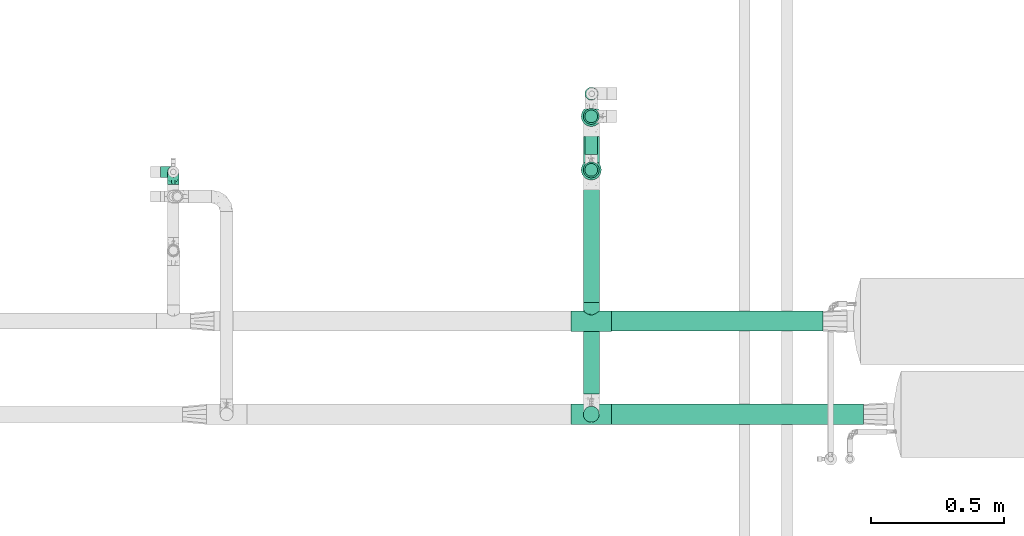
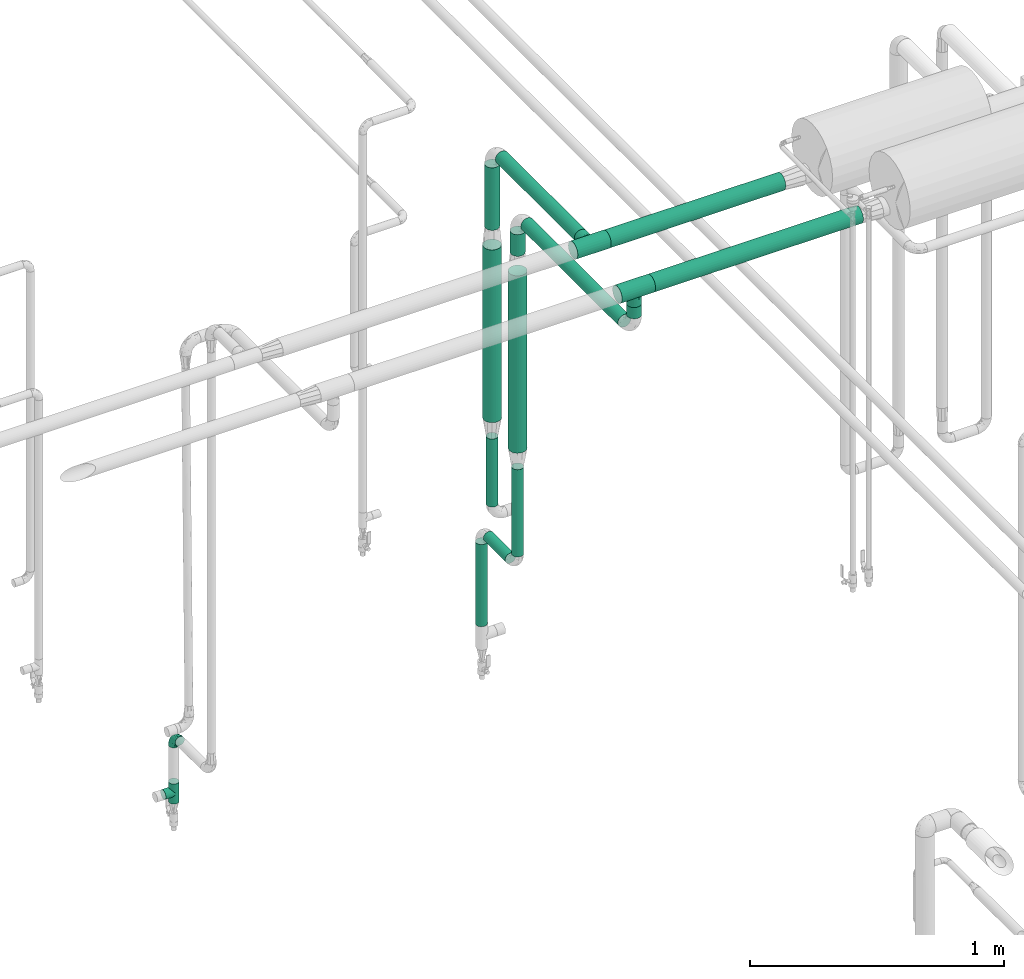
# One storey, part 568 of 827: 13 flow segments, 4 flow fittings.
"""IFC2X3 building model written with IfcOpenShell, lengths in millimetres."""

from ifc_helpers import new_model, entity, si_unit, converted_unit, derived_unit, direction, frame, origin, origin_2d_with_axis, place, context, subcontext, project, spatial, circle, extrude, faceted_brep, source, transform, mapped, material, type_object, type_shapes, element, save


model = new_model("IFC2X3")

# Units and contexts
model_context = context("Model", 3, precision=0.01, world=origin(), true_north=direction((6.12303176911189e-17, 1.0)))
body_context = subcontext(model_context, "Body", "Model", "MODEL_VIEW")
ifc_project = project(units=[si_unit("LENGTHUNIT", "METRE", prefix="MILLI"), si_unit("AREAUNIT", "SQUARE_METRE"), si_unit("VOLUMEUNIT", "CUBIC_METRE"), converted_unit("PLANEANGLEUNIT", "DEGREE", entity("IfcRatioMeasure", 0.0174532925199433), si_unit("PLANEANGLEUNIT", "RADIAN"), dimensions=[0, 0, 0, 0, 0, 0, 0]), si_unit("MASSUNIT", "GRAM", prefix="KILO"), derived_unit("MASSDENSITYUNIT", [(si_unit("MASSUNIT", "GRAM", prefix="KILO"), 1), (si_unit("LENGTHUNIT", "METRE"), -3)]), derived_unit("MOMENTOFINERTIAUNIT", [(si_unit("LENGTHUNIT", "METRE"), 4)]), si_unit("TIMEUNIT", "SECOND"), si_unit("FREQUENCYUNIT", "HERTZ"), si_unit("THERMODYNAMICTEMPERATUREUNIT", "DEGREE_CELSIUS"), derived_unit("THERMALTRANSMITTANCEUNIT", [(si_unit("MASSUNIT", "GRAM", prefix="KILO"), 1), (si_unit("THERMODYNAMICTEMPERATUREUNIT", "KELVIN"), -1), (si_unit("TIMEUNIT", "SECOND"), -3)]), derived_unit("VOLUMETRICFLOWRATEUNIT", [(si_unit("LENGTHUNIT", "METRE"), 3), (si_unit("TIMEUNIT", "SECOND"), -1)]), derived_unit("MASSFLOWRATEUNIT", [(si_unit("MASSUNIT", "GRAM", prefix="KILO"), 1), (si_unit("TIMEUNIT", "SECOND"), -1)]), derived_unit("ROTATIONALFREQUENCYUNIT", [(si_unit("TIMEUNIT", "SECOND"), -1)]), si_unit("ELECTRICCURRENTUNIT", "AMPERE"), si_unit("ELECTRICVOLTAGEUNIT", "VOLT"), si_unit("POWERUNIT", "WATT"), si_unit("FORCEUNIT", "NEWTON", prefix="KILO"), si_unit("ILLUMINANCEUNIT", "LUX"), si_unit("LUMINOUSFLUXUNIT", "LUMEN"), si_unit("LUMINOUSINTENSITYUNIT", "CANDELA"), derived_unit("USERDEFINED", [(si_unit("MASSUNIT", "GRAM", prefix="KILO"), -1), (si_unit("LENGTHUNIT", "METRE"), -2), (si_unit("TIMEUNIT", "SECOND"), 3), (si_unit("LUMINOUSFLUXUNIT", "LUMEN"), 1)]), derived_unit("LINEARVELOCITYUNIT", [(si_unit("LENGTHUNIT", "METRE"), 1), (si_unit("TIMEUNIT", "SECOND"), -1)]), si_unit("PRESSUREUNIT", "PASCAL"), derived_unit("USERDEFINED", [(si_unit("LENGTHUNIT", "METRE"), -2), (si_unit("MASSUNIT", "GRAM", prefix="KILO"), 1), (si_unit("TIMEUNIT", "SECOND"), -2)]), derived_unit("LINEARFORCEUNIT", [(si_unit("MASSUNIT", "GRAM", prefix="KILO"), 1), (si_unit("LENGTHUNIT", "METRE"), 1), (si_unit("TIMEUNIT", "SECOND"), -2), (si_unit("LENGTHUNIT", "METRE"), -1)]), derived_unit("PLANARFORCEUNIT", [(si_unit("MASSUNIT", "GRAM", prefix="KILO"), 1), (si_unit("LENGTHUNIT", "METRE"), 1), (si_unit("TIMEUNIT", "SECOND"), -2), (si_unit("LENGTHUNIT", "METRE"), -2)])], contexts=[model_context])

# Site, building, storey
site_placement = place(None, origin())
site = spatial("IfcSite", under=ifc_project, at=site_placement, CompositionType="ELEMENT")
building_placement = place(site_placement, origin())
building = spatial("IfcBuilding", under=site, at=building_placement, CompositionType="ELEMENT")
storey_placement = place(building_placement, frame((0.0, 0.0, 28200.0)))
storey = spatial("IfcBuildingStorey", under=building, at=storey_placement, Name="08", CompositionType="ELEMENT", Elevation=28200.0)

# Flow segments
pipe_segment_type = type_object("IfcPipeSegmentType", PredefinedType="NOTDEFINED")
flow_segment_1_placement = place(storey_placement, frame((15101.95, 14710.46, 2760.65)))
element("IfcFlowSegment", 1, at=flow_segment_1_placement, inside=storey, type_object=pipe_segment_type, context=body_context, shape_type="SweptSolid", body=[
    extrude(circle(Radius=37.75, at=origin_2d_with_axis()), frame((0.0, 39.43, 39.35), z_axis=(0.999999993712363, -0.000112139528928996, 0.0), x_axis=(-0.000112139528928996, -0.999999993712363, 0.0)), (0.0, 0.0, 1.0), 795.037507659304),
])
flow_segment_2_placement = place(storey_placement, frame((15000.21, 15292.44, 969.08)))
element("IfcFlowSegment", 2, at=flow_segment_2_placement, inside=storey, type_object=pipe_segment_type, context=body_context, shape_type="SweptSolid", body=[
    extrude(circle(Radius=24.0, at=origin_2d_with_axis()), frame((25.6, 25.6, 0.0), z_axis=(0.0, 0.0, 1.0), x_axis=(-1.0, 0.0, 0.0)), (0.0, 0.0, 1.0), 419.563411712063),
])
flow_segment_3_placement = place(storey_placement, frame((15000.21, 15375.04, 886.48)))
element("IfcFlowSegment", 3, at=flow_segment_3_placement, inside=storey, type_object=pipe_segment_type, context=body_context, shape_type="SweptSolid", body=[
    extrude(circle(Radius=24.0, at=origin_2d_with_axis()), frame((25.6, 0.0, 25.6), z_axis=(0.0, 1.0, 0.0), x_axis=(1.0, 0.0, 0.0)), (0.0, 0.0, 1.0), 172.077214265968),
])
flow_segment_4_placement = place(storey_placement, frame((15000.21, 15578.52, 459.5)))
element("IfcFlowSegment", 4, at=flow_segment_4_placement, inside=storey, type_object=pipe_segment_type, context=body_context, shape_type="SweptSolid", body=[
    extrude(circle(Radius=24.0, at=origin_2d_with_axis()), frame((25.6, 25.6, 0.0)), (0.0, 0.0, 1.0), 395.578790961028),
])
flow_segment_5_placement = place(storey_placement, frame((15000.21, 15493.59, 1087.0)))
element("IfcFlowSegment", 5, at=flow_segment_5_placement, inside=storey, type_object=pipe_segment_type, context=body_context, shape_type="SweptSolid", body=[
    extrude(circle(Radius=24.0, at=origin_2d_with_axis()), frame((25.6, 25.6, 0.0), z_axis=(0.0, 0.0, 1.0), x_axis=(-1.0, 0.0, 0.0)), (0.0, 0.0, 1.0), 326.642202673085),
])
flow_segment_6_placement = place(storey_placement, frame((14994.36, 14476.0, 2568.4)))
element("IfcFlowSegment", 6, at=flow_segment_6_placement, inside=storey, type_object=pipe_segment_type, context=body_context, shape_type="SweptSolid", body=[
    extrude(circle(Radius=30.0, at=origin_2d_with_axis()), frame((31.6, 0.0, 31.6), z_axis=(0.0, 1.0, 0.0), x_axis=(-1.0, 0.0, 0.0)), (0.0, 0.0, 1.0), 766.041462070277),
])
flow_segment_7_placement = place(storey_placement, frame((14994.36, 14819.89, 2768.4)))
element("IfcFlowSegment", 7, at=flow_segment_7_placement, inside=storey, type_object=pipe_segment_type, context=body_context, shape_type="SweptSolid", body=[
    extrude(circle(Radius=30.0, at=origin_2d_with_axis()), frame((31.6, 0.0, 31.6), z_axis=(0.0, 1.0, 0.0), x_axis=(1.0, 0.0, 0.0)), (0.0, 0.0, 1.0), 623.293460725732),
])
flow_segment_8_placement = place(storey_placement, frame((14994.36, 15487.59, 2423.0)))
element("IfcFlowSegment", 8, at=flow_segment_8_placement, inside=storey, type_object=pipe_segment_type, context=body_context, shape_type="SweptSolid", body=[
    extrude(circle(Radius=30.0, at=origin_2d_with_axis()), frame((31.6, 31.6, 0.0)), (0.0, 0.0, 1.0), 300.99713307737),
])
flow_segment_9_placement = place(storey_placement, frame((14986.45, 15278.69, 1477.64)))
element("IfcFlowSegment", 9, at=flow_segment_9_placement, inside=storey, type_object=pipe_segment_type, context=body_context, shape_type="SweptSolid", body=[
    extrude(circle(Radius=37.75, at=origin_2d_with_axis()), frame((39.35, 39.35, 0.01), z_axis=(0.000190795727172156, 0.0, 0.999999981798495), x_axis=(-0.999999981798495, 0.0, 0.000190795727172156)), (0.0, 0.0, 1.0), 853.357118238638),
])
flow_segment_10_placement = place(storey_placement, frame((14994.36, 15286.44, 2419.99)))
element("IfcFlowSegment", 10, at=flow_segment_10_placement, inside=storey, type_object=pipe_segment_type, context=body_context, shape_type="SweptSolid", body=[
    extrude(circle(Radius=30.0, at=origin_2d_with_axis()), frame((31.61, 31.6, 0.0), z_axis=(-0.000163277107937196, 0.0, 0.999999986670293), x_axis=(0.999999986670293, 0.0, 0.000163277107937196)), (0.0, 0.0, 1.0), 104.000003006218),
])
flow_segment_11_placement = place(storey_placement, frame((14994.36, 14368.4, 2676.0)))
element("IfcFlowSegment", 11, at=flow_segment_11_placement, inside=storey, type_object=pipe_segment_type, context=body_context, shape_type="SweptSolid", body=[
    extrude(circle(Radius=30.0, at=origin_2d_with_axis()), frame((31.6, 31.6, 0.0), z_axis=(0.0, 0.0, 1.0), x_axis=(-1.0, 0.0, 0.0)), (0.0, 0.0, 1.0), 53.9656816819943),
])
flow_segment_12_placement = place(storey_placement, frame((14986.46, 15479.84, 1502.64)))
element("IfcFlowSegment", 12, at=flow_segment_12_placement, inside=storey, type_object=pipe_segment_type, context=body_context, shape_type="SweptSolid", body=[
    extrude(circle(Radius=37.75, at=origin_2d_with_axis()), frame((39.35, 39.35, 0.0)), (0.0, 0.0, 1.0), 831.360664249551),
])
flow_segment_13_placement = place(storey_placement, frame((15101.95, 14360.65, 2760.62)))
element("IfcFlowSegment", 13, at=flow_segment_13_placement, inside=storey, type_object=pipe_segment_type, context=body_context, shape_type="SweptSolid", body=[
    extrude(circle(Radius=37.75, at=origin_2d_with_axis()), frame((0.0, 39.35, 39.35), z_axis=(1.0, 0.0, 0.0), x_axis=(0.0, 1.0, 0.0)), (0.0, 0.0, 1.0), 946.308028629994),
])

# Flow fittings
ifc_material = material()
pipe_fitting_type_1 = type_object("IfcPipeFittingType", Name="ADSK_1", PredefinedType="NOTDEFINED", material=ifc_material)
shared_shape_1 = source(origin(), body_context, "Body", "Brep", [
    faceted_brep([(-48.0, 10.6, -18.36), (-48.0, 5.49, -20.48), (-48.0, 0.0, -21.2), (-48.0, -5.49, -20.48), (-48.0, -10.6, -18.36), (-48.0, -14.99, -14.99), (-48.0, -18.36, -10.6), (-48.0, -20.48, -5.49), (-48.0, -21.2, 0.0), (-48.0, -20.48, 5.49), (-48.0, -18.36, 10.6), (-48.0, -14.99, 14.99), (-48.0, -10.6, 18.36), (-48.0, -5.49, 20.48), (-48.0, 0.0, 21.2), (-48.0, 5.49, 20.48), (-48.0, 10.6, 18.36), (-48.0, 14.99, 14.99), (-48.0, 18.36, 10.6), (-48.0, 20.48, 5.49), (-48.0, 21.2, 0.0), (-48.0, 20.48, -5.49), (-48.0, 18.36, -10.6), (-48.0, 14.99, -14.99), (0.0, 48.0, -21.2), (-5.49, 48.0, -20.48), (-10.6, 48.0, -18.36), (-14.99, 48.0, -14.99), (-18.36, 48.0, -10.6), (-20.48, 48.0, -5.49), (-21.2, 48.0, 0.0), (-20.48, 48.0, 5.49), (-18.36, 48.0, 10.6), (-14.99, 48.0, 14.99), (-10.6, 48.0, 18.36), (-5.49, 48.0, 20.48), (0.0, 48.0, 21.2), (5.49, 48.0, 20.48), (10.6, 48.0, 18.36), (14.99, 48.0, 14.99), (18.36, 48.0, 10.6), (20.48, 48.0, 5.49), (21.2, 48.0, 0.0), (20.48, 48.0, -5.49), (18.36, 48.0, -10.6), (14.99, 48.0, -14.99), (10.6, 48.0, -18.36), (5.49, 48.0, -20.48), (-35.25, -16.22, 12.01), (-34.76, -18.57, 0.0), (-20.87, -12.37, 10.9), (-31.49, -11.78, 15.9), (-37.0, -2.58, 20.86), (-33.89, 3.62, 21.15), (-31.81, -18.14, 6.76), (-5.78, 5.78, 17.67), (-19.42, -4.1, 17.86), (-9.6, -3.39, 13.73), (-35.44, -7.73, 19.13), (11.78, 31.49, 15.9), (-5.93, -5.46, 6.95), (-18.45, -13.78, 5.46), (-10.29, -8.43, 0.0), (-24.6, 0.55, 20.62), (-37.28, 17.94, 13.81), (-33.38, 22.85, 9.59), (-41.46, 20.06, 8.75), (-29.51, 20.45, 15.16), (-15.04, 10.79, 21.13), (-7.08, 16.98, 20.93), (-8.39, 23.51, 21.15), (-40.86, 13.03, 17.26), (-8.05, 41.26, 19.83), (-3.21, 35.97, 21.14), (8.53, 19.66, 14.74), (4.1, 19.42, 17.86), (-37.72, 22.66, 4.78), (-37.07, 8.58, 19.98), (-13.0, 5.43, 19.97), (-3.78, 13.93, 19.7), (3.02, 8.69, 13.43), (-2.27, -0.05, 10.65), (6.22, 6.99, 7.09), (-22.25, 34.6, 9.45), (18.14, 31.81, 6.76), (16.22, 35.25, 12.01), (12.37, 20.87, 10.9), (7.73, 35.44, 19.13), (-21.52, -15.93, 0.0), (2.58, 37.0, 20.86), (18.57, 34.76, 0.0), (13.78, 18.45, 5.46), (15.93, 21.52, 0.0), (-20.03, -8.54, 14.9), (-28.6, 28.6, 5.16), (-24.79, 34.6, 0.0), (-34.6, 24.79, 0.0), (-22.81, 37.41, 4.68), (-23.36, 26.33, 14.79), (-13.68, 37.05, 17.49), (-17.72, 38.12, 13.73), (-26.25, 27.3, 11.24), (-9.71, 32.34, 20.14), (-17.26, 25.6, 18.71), (-26.33, 9.99, 20.77), (-24.06, 6.05, 21.2), (-25.02, 15.46, 19.56), (-24.3, 20.72, 17.57), (-31.95, 15.23, 17.8), (-13.53, 24.7, 20.21), (-17.6, 17.6, 20.6), (-0.55, 24.6, 20.62), (-11.41, -7.48, 10.43), (0.93, -0.93, 0.0), (8.43, 10.29, 0.0), (-11.41, -7.48, -10.43), (-20.1, -8.84, -14.66), (-9.6, -3.39, -13.73), (7.73, 35.44, -19.13), (4.1, 19.42, -17.86), (-0.55, 24.6, -20.62), (-38.12, 17.72, -13.73), (-37.05, 13.68, -17.49), (-32.34, 9.71, -20.14), (-41.26, 8.05, -19.83), (-37.41, 22.81, -4.68), (-23.51, 8.39, -21.15), (-35.97, 3.21, -21.14), (-28.6, 28.6, -5.16), (-31.81, -18.14, -6.76), (-18.45, -13.78, -5.46), (-25.6, 17.26, -18.71), (-19.42, -4.1, -17.86), (-17.94, 37.28, -13.81), (-22.85, 33.38, -9.59), (-20.06, 41.46, -8.75), (-31.49, -11.78, -15.9), (-35.25, -16.22, -12.01), (8.53, 19.66, -14.74), (11.78, 31.49, -15.9), (-9.99, 26.33, -20.77), (-6.05, 24.06, -21.2), (-10.79, 15.04, -21.13), (-37.0, -2.58, -20.86), (-16.98, 7.08, -20.93), (-5.43, 13.0, -19.97), (-13.93, 3.78, -19.7), (-20.87, -12.37, -10.9), (-26.33, 23.36, -14.79), (-22.66, 37.72, -4.78), (13.78, 18.45, -5.46), (18.14, 31.81, -6.76), (-15.46, 25.02, -19.56), (-20.72, 24.3, -17.57), (16.22, 35.25, -12.01), (-13.03, 40.86, -17.26), (-8.58, 37.07, -19.98), (2.58, 37.0, -20.86), (-3.62, 33.89, -21.15), (-34.6, 22.25, -9.45), (6.22, 6.99, -7.09), (-20.45, 29.51, -15.16), (-35.44, -7.73, -19.13), (12.37, 20.87, -10.9), (-27.3, 26.25, -11.24), (-15.23, 31.95, -17.8), (-24.7, 13.53, -20.21), (-24.6, 0.55, -20.62), (-5.78, 5.78, -17.67), (-17.6, 17.6, -20.6), (3.02, 8.69, -13.43), (-5.93, -5.46, -6.95), (-2.27, -0.05, -10.65)], [[[0, 1, 2, 3, 4, 5, 6, 7, 8, 9, 10, 11, 12, 13, 14, 15, 16, 17, 18, 19, 20, 21, 22, 23]], [[24, 25, 26, 27, 28, 29, 30, 31, 32, 33, 34, 35, 36, 37, 38, 39, 40, 41, 42, 43, 44, 45, 46, 47]], [[10, 48, 11]], [[9, 8, 49]], [[48, 50, 51]], [[14, 52, 53]], [[10, 54, 48]], [[9, 54, 10]], [[55, 56, 57]], [[51, 12, 11]], [[51, 58, 12]], [[59, 39, 38]], [[60, 61, 62]], [[58, 56, 63]], [[64, 65, 66]], [[67, 65, 64]], [[68, 69, 70]], [[16, 71, 17]], [[13, 52, 14]], [[35, 72, 73]], [[14, 53, 15]], [[17, 64, 18]], [[74, 59, 75]], [[20, 19, 76]], [[66, 19, 18]], [[77, 15, 53]], [[15, 77, 16]], [[69, 78, 79]], [[80, 81, 82]], [[32, 31, 83]], [[84, 85, 86]], [[59, 87, 75]], [[61, 54, 88]], [[36, 89, 37]], [[84, 41, 40]], [[36, 35, 73]], [[90, 41, 84]], [[40, 39, 85]], [[12, 58, 13]], [[85, 84, 40]], [[91, 84, 86]], [[84, 92, 90]], [[87, 38, 37]], [[93, 56, 51]], [[65, 94, 76]], [[94, 95, 96]], [[84, 91, 92]], [[95, 97, 30]], [[98, 99, 100]], [[76, 94, 96]], [[101, 98, 83]], [[100, 99, 33]], [[102, 70, 73]], [[103, 102, 99]], [[94, 97, 95]], [[72, 99, 102]], [[72, 35, 34]], [[34, 33, 99]], [[9, 49, 54]], [[87, 59, 38]], [[104, 105, 68]], [[106, 103, 107]], [[106, 77, 104]], [[71, 64, 17]], [[108, 107, 67]], [[33, 32, 100]], [[109, 103, 110]], [[102, 109, 70]], [[89, 73, 111]], [[50, 48, 54]], [[51, 11, 48]], [[56, 58, 51]], [[88, 54, 49]], [[52, 58, 63]], [[50, 112, 93]], [[56, 55, 78]], [[39, 59, 85]], [[86, 85, 59]], [[89, 87, 37]], [[42, 41, 90]], [[111, 79, 75]], [[111, 75, 87]], [[75, 55, 80]], [[104, 77, 53]], [[71, 77, 108]], [[32, 83, 100]], [[98, 100, 83]], [[99, 98, 103]], [[106, 107, 108]], [[68, 70, 110]], [[111, 73, 70]], [[68, 110, 104]], [[68, 63, 78]], [[57, 93, 112]], [[80, 55, 57]], [[61, 50, 54]], [[80, 82, 86]], [[81, 57, 112]], [[74, 86, 59]], [[60, 113, 82]], [[82, 114, 91]], [[101, 94, 65]], [[97, 94, 83]], [[73, 89, 36]], [[87, 89, 111]], [[58, 52, 13]], [[53, 52, 63]], [[104, 53, 105]], [[106, 104, 110]], [[20, 76, 96]], [[76, 19, 66]], [[103, 106, 110]], [[77, 106, 108]], [[103, 98, 107]], [[67, 107, 98]], [[67, 98, 101]], [[108, 67, 64]], [[53, 63, 105]], [[63, 68, 105]], [[83, 31, 97]], [[30, 97, 31]], [[62, 113, 60]], [[112, 61, 60]], [[61, 88, 62]], [[86, 82, 91]], [[56, 78, 63]], [[114, 82, 113]], [[114, 92, 91]], [[79, 78, 55]], [[75, 79, 55]], [[69, 79, 111]], [[70, 69, 111]], [[78, 69, 68]], [[77, 71, 16]], [[64, 71, 108]], [[64, 66, 18]], [[76, 66, 65]], [[99, 72, 34]], [[73, 72, 102]], [[94, 101, 83]], [[67, 101, 65]], [[75, 80, 74]], [[80, 86, 74]], [[70, 109, 110]], [[102, 103, 109]], [[50, 93, 51]], [[57, 56, 93]], [[61, 112, 50]], [[81, 112, 60]], [[82, 81, 60]], [[80, 57, 81]], [[115, 116, 117]], [[118, 119, 120]], [[121, 122, 23]], [[123, 124, 122]], [[96, 125, 20]], [[123, 126, 127]], [[128, 96, 95]], [[129, 130, 88]], [[123, 122, 131]], [[116, 132, 117]], [[133, 134, 135]], [[0, 124, 1]], [[5, 136, 137]], [[138, 119, 139]], [[129, 88, 49]], [[140, 141, 142]], [[6, 5, 137]], [[46, 118, 47]], [[143, 3, 2]], [[144, 145, 146]], [[6, 129, 7]], [[129, 137, 147]], [[127, 2, 1]], [[148, 122, 121]], [[128, 125, 96]], [[134, 128, 149]], [[95, 149, 128]], [[150, 151, 92]], [[30, 29, 149]], [[152, 131, 153]], [[27, 133, 28]], [[154, 45, 44]], [[136, 5, 4]], [[27, 26, 155]], [[156, 26, 25]], [[24, 157, 158]], [[24, 47, 157]], [[22, 21, 159]], [[160, 150, 114]], [[134, 133, 161]], [[142, 144, 126]], [[46, 139, 118]], [[162, 136, 4]], [[156, 25, 158]], [[1, 124, 127]], [[115, 147, 116]], [[45, 154, 139]], [[139, 46, 45]], [[154, 163, 139]], [[162, 4, 3]], [[42, 90, 43]], [[130, 129, 147]], [[49, 7, 129]], [[43, 151, 44]], [[0, 23, 122]], [[24, 158, 25]], [[136, 162, 132]], [[135, 29, 28]], [[43, 90, 151]], [[164, 148, 159]], [[152, 156, 140]], [[155, 133, 27]], [[165, 153, 161]], [[23, 22, 121]], [[123, 131, 166]], [[123, 166, 126]], [[143, 127, 167]], [[147, 137, 136]], [[8, 7, 49]], [[129, 6, 137]], [[143, 162, 3]], [[167, 146, 132]], [[167, 132, 162]], [[132, 168, 117]], [[44, 151, 154]], [[92, 151, 90]], [[163, 154, 151]], [[119, 118, 139]], [[157, 118, 120]], [[138, 139, 163]], [[119, 168, 145]], [[140, 156, 158]], [[155, 156, 165]], [[22, 159, 121]], [[148, 121, 159]], [[122, 148, 131]], [[152, 153, 165]], [[142, 126, 169]], [[167, 127, 126]], [[142, 169, 140]], [[142, 120, 145]], [[168, 170, 117]], [[160, 171, 172]], [[115, 172, 171]], [[171, 62, 130]], [[119, 170, 168]], [[170, 163, 160]], [[150, 163, 151]], [[113, 171, 160]], [[164, 128, 134]], [[125, 128, 159]], [[127, 143, 2]], [[162, 143, 167]], [[118, 157, 47]], [[158, 157, 120]], [[140, 158, 141]], [[152, 140, 169]], [[30, 149, 95]], [[149, 29, 135]], [[131, 152, 169]], [[156, 152, 165]], [[131, 148, 153]], [[161, 153, 148]], [[161, 148, 164]], [[165, 161, 133]], [[158, 120, 141]], [[120, 142, 141]], [[159, 21, 125]], [[20, 125, 21]], [[115, 130, 147]], [[114, 113, 160]], [[62, 171, 113]], [[62, 88, 130]], [[160, 163, 150]], [[150, 92, 114]], [[119, 145, 120]], [[146, 145, 168]], [[132, 146, 168]], [[144, 146, 167]], [[126, 144, 167]], [[145, 144, 142]], [[156, 155, 26]], [[133, 155, 165]], [[133, 135, 28]], [[149, 135, 134]], [[122, 124, 0]], [[127, 124, 123]], [[128, 164, 159]], [[161, 164, 134]], [[163, 170, 138]], [[170, 119, 138]], [[131, 169, 166]], [[126, 166, 169]], [[147, 136, 116]], [[132, 116, 136]], [[172, 115, 117]], [[130, 115, 171]], [[117, 170, 172]], [[160, 172, 170]]]),
])
type_shapes(pipe_fitting_type_1, [shared_shape_1])
flow_fitting_1_placement = place(storey_placement, frame((13455.97, 15310.4, 650.0), z_axis=(-1.0, 0.0, 0.0), x_axis=(0.0, 1.0, 0.0)))
element("IfcFlowFitting", 14, at=flow_fitting_1_placement, inside=storey, type_object=pipe_fitting_type_1, material=ifc_material, Name="ADSK_1", ObjectType="ADSK_1", context=body_context, shape_type="MappedRepresentation", body=[
    mapped(shared_shape_1, transform((0.0, 0.0, 0.0), scale=1.0)),
])
pipe_fitting_type_2 = type_object("IfcPipeFittingType", Name="ADSK_1", PredefinedType="NOTDEFINED", material=ifc_material)
shared_shape_2 = source(origin(), body_context, "Body", "Brep", [
    faceted_brep([(-48.0, 10.6, -18.36), (-48.0, 5.49, -20.48), (-48.0, 0.0, -21.2), (-48.0, -5.49, -20.48), (-48.0, -10.6, -18.36), (-48.0, -14.99, -14.99), (-48.0, -18.36, -10.6), (-48.0, -20.48, -5.49), (-48.0, -21.2, 0.0), (-48.0, -20.48, 5.49), (-48.0, -18.36, 10.6), (-48.0, -14.99, 14.99), (-48.0, -10.6, 18.36), (-48.0, -5.49, 20.48), (-48.0, 0.0, 21.2), (-48.0, 5.49, 20.48), (-48.0, 10.6, 18.36), (-48.0, 14.99, 14.99), (-48.0, 18.36, 10.6), (-48.0, 20.48, 5.49), (-48.0, 21.2, 0.0), (-48.0, 20.48, -5.49), (-48.0, 18.36, -10.6), (-48.0, 14.99, -14.99), (48.0, 0.0, -21.2), (48.0, 5.49, -20.48), (48.0, 10.6, -18.36), (48.0, 14.99, -14.99), (48.0, 18.36, -10.6), (48.0, 20.48, -5.49), (48.0, 21.2, 0.0), (48.0, 20.48, 5.49), (48.0, 18.36, 10.6), (48.0, 14.99, 14.99), (48.0, 10.6, 18.36), (48.0, 5.49, 20.48), (48.0, 0.0, 21.2), (48.0, -5.49, 20.48), (48.0, -10.6, 18.36), (48.0, -14.99, 14.99), (48.0, -18.36, 10.6), (48.0, -20.48, 5.49), (48.0, -21.2, 0.0), (48.0, -20.48, -5.49), (48.0, -18.36, -10.6), (48.0, -14.99, -14.99), (48.0, -10.6, -18.36), (48.0, -5.49, -20.48), (20.43, -20.43, 5.66), (21.2, -21.2, 0.0), (-21.2, -21.2, 0.0), (18.35, -18.35, 10.62), (11.88, -11.88, 17.56), (15.38, -15.38, 14.59), (-20.43, -20.43, 5.66), (-18.35, -18.35, 10.62), (-15.38, -15.38, 14.59), (-11.88, -11.88, 17.56), (-8.06, -8.06, 19.61), (8.06, -8.06, 19.61), (4.07, -4.07, 20.81), (0.0, 0.0, 21.2), (-4.07, -4.07, 20.81), (4.07, -4.07, -20.81), (0.0, 0.0, -21.2), (-4.07, -4.07, -20.81), (-8.06, -8.06, -19.61), (8.06, -8.06, -19.61), (11.88, -11.88, -17.56), (15.38, -15.38, -14.59), (18.35, -18.35, -10.62), (20.43, -20.43, -5.66), (-11.88, -11.88, -17.56), (-15.38, -15.38, -14.59), (-20.43, -20.43, -5.66), (-18.35, -18.35, -10.62), (0.0, -48.0, -21.2), (5.49, -48.0, -20.48), (10.6, -48.0, -18.36), (14.99, -48.0, -14.99), (18.36, -48.0, -10.6), (20.48, -48.0, -5.49), (21.2, -48.0, 0.0), (20.48, -48.0, 5.49), (18.36, -48.0, 10.6), (14.99, -48.0, 14.99), (10.6, -48.0, 18.36), (5.49, -48.0, 20.48), (0.0, -48.0, 21.2), (-5.49, -48.0, 20.48), (-10.6, -48.0, 18.36), (-14.99, -48.0, 14.99), (-18.36, -48.0, 10.6), (-20.48, -48.0, 5.49), (-21.2, -48.0, 0.0), (-20.48, -48.0, -5.49), (-18.36, -48.0, -10.6), (-14.99, -48.0, -14.99), (-10.6, -48.0, -18.36), (-5.49, -48.0, -20.48)], [[[0, 1, 2, 3, 4, 5, 6, 7, 8, 9, 10, 11, 12, 13, 14, 15, 16, 17, 18, 19, 20, 21, 22, 23]], [[24, 25, 26, 27, 28, 29, 30, 31, 32, 33, 34, 35, 36, 37, 38, 39, 40, 41, 42, 43, 44, 45, 46, 47]], [[41, 40, 48]], [[42, 41, 49]], [[50, 9, 8]], [[49, 41, 48]], [[40, 51, 48]], [[39, 38, 52]], [[51, 40, 53]], [[52, 53, 39]], [[53, 40, 39]], [[50, 54, 9]], [[9, 54, 10]], [[54, 55, 10]], [[56, 57, 11]], [[11, 10, 56]], [[11, 57, 12]], [[56, 10, 55]], [[12, 57, 58]], [[52, 38, 59]], [[60, 36, 61]], [[62, 61, 14]], [[59, 37, 60]], [[37, 59, 38]], [[60, 37, 36]], [[61, 36, 35, 15, 14]], [[32, 31, 19, 18]], [[17, 16, 34, 33]], [[18, 17, 33, 32]], [[35, 34, 16, 15]], [[20, 19, 31, 30]], [[62, 13, 58]], [[13, 62, 14]], [[58, 13, 12]], [[27, 23, 22, 28]], [[22, 21, 29, 28]], [[0, 23, 27, 26]], [[20, 30, 29, 21]], [[24, 47, 63]], [[24, 64, 2, 1, 25]], [[64, 24, 63]], [[2, 64, 65]], [[26, 25, 1, 0]], [[65, 66, 3]], [[2, 65, 3]], [[66, 4, 3]], [[63, 47, 67]], [[46, 45, 68]], [[69, 68, 45]], [[44, 70, 69]], [[69, 45, 44]], [[46, 68, 67]], [[43, 42, 49]], [[7, 50, 8]], [[43, 71, 44]], [[71, 43, 49]], [[44, 71, 70]], [[72, 4, 66]], [[72, 5, 4]], [[5, 72, 73]], [[5, 73, 6]], [[74, 50, 7]], [[75, 74, 6]], [[74, 7, 6]], [[75, 6, 73]], [[46, 67, 47]], [[76, 77, 78, 79, 80, 81, 82, 83, 84, 85, 86, 87, 88, 89, 90, 91, 92, 93, 94, 95, 96, 97, 98, 99]], [[50, 94, 93]], [[54, 50, 93]], [[91, 90, 57]], [[56, 92, 91]], [[54, 93, 92]], [[58, 90, 89]], [[55, 54, 92]], [[56, 55, 92]], [[58, 57, 90]], [[88, 61, 62]], [[58, 89, 62]], [[56, 91, 57]], [[62, 89, 88]], [[60, 88, 87]], [[86, 59, 87]], [[84, 83, 48]], [[53, 85, 84]], [[52, 86, 85]], [[49, 83, 82]], [[59, 60, 87]], [[52, 59, 86]], [[49, 48, 83]], [[51, 53, 84]], [[48, 51, 84]], [[52, 85, 53]], [[88, 60, 61]], [[82, 81, 49]], [[71, 49, 81]], [[69, 80, 79]], [[79, 78, 68]], [[71, 81, 80]], [[67, 78, 77]], [[70, 71, 80]], [[69, 70, 80]], [[67, 68, 78]], [[76, 64, 63]], [[67, 77, 63]], [[69, 79, 68]], [[63, 77, 76]], [[65, 76, 99]], [[98, 66, 99]], [[96, 95, 74]], [[73, 97, 96]], [[72, 98, 97]], [[50, 95, 94]], [[66, 65, 99]], [[72, 66, 98]], [[50, 74, 95]], [[75, 73, 96]], [[74, 75, 96]], [[72, 97, 73]], [[76, 65, 64]]]),
])
type_shapes(pipe_fitting_type_2, [shared_shape_2])
flow_fitting_2_placement = place(storey_placement, frame((13455.97, 15310.4, 379.5), z_axis=(0.0, 1.0, 0.0), x_axis=(0.0, 0.0, 1.0)))
element("IfcFlowFitting", 15, at=flow_fitting_2_placement, inside=storey, type_object=pipe_fitting_type_2, material=ifc_material, Name="ADSK_1", ObjectType="ADSK_1", context=body_context, shape_type="MappedRepresentation", body=[
    mapped(shared_shape_2, transform((0.0, 0.0, 0.0), scale=1.0)),
])
pipe_fitting_type_3 = type_object("IfcPipeFittingType", Name="ADSK_1", PredefinedType="NOTDEFINED", material=ifc_material)
shared_shape_3 = source(origin(), body_context, "Body", "Brep", [
    faceted_brep([(-76.0, 9.85, -36.75), (-76.0, 0.0, -38.05), (-76.0, -9.85, -36.75), (-76.0, -19.03, -32.95), (-76.0, -26.91, -26.91), (-76.0, -32.95, -19.03), (-76.0, -36.75, -9.85), (-76.0, -38.05, 0.0), (-76.0, -36.75, 9.85), (-76.0, -32.95, 19.02), (-76.0, -26.91, 26.91), (-76.0, -19.03, 32.95), (-76.0, -9.85, 36.75), (-76.0, 0.0, 38.05), (-76.0, 9.85, 36.75), (-76.0, 19.02, 32.95), (-76.0, 26.91, 26.91), (-76.0, 32.95, 19.02), (-76.0, 36.75, 9.85), (-76.0, 38.05, 0.0), (-76.0, 36.75, -9.85), (-76.0, 32.95, -19.03), (-76.0, 26.91, -26.91), (-76.0, 19.02, -32.95), (76.0, 26.91, -26.91), (76.0, 32.95, -19.03), (76.0, 36.75, -9.85), (76.0, 38.05, 0.0), (76.0, 36.75, 9.85), (76.0, 32.95, 19.02), (76.0, 26.91, 26.91), (76.0, 19.02, 32.95), (76.0, 9.85, 36.75), (76.0, 0.0, 38.05), (76.0, -9.85, 36.75), (76.0, -19.03, 32.95), (76.0, -26.91, 26.91), (76.0, -32.95, 19.02), (76.0, -36.75, 9.85), (76.0, -38.05, 0.0), (76.0, -36.75, -9.85), (76.0, -32.95, -19.03), (76.0, -26.91, -26.91), (76.0, -19.03, -32.95), (76.0, -9.85, -36.75), (76.0, 0.0, -38.05), (76.0, 9.85, -36.75), (76.0, 19.02, -32.95), (30.15, -38.05, 0.0), (-30.15, -38.05, 0.0), (28.17, -36.5, 10.76), (29.16, -37.27, 5.38), (22.87, -32.58, 19.65), (15.21, -27.75, 26.03), (5.49, -23.85, 29.65), (-29.16, -37.27, 5.38), (-28.17, -36.5, 10.75), (-15.21, -27.75, 26.03), (-5.5, -23.85, 29.64), (-22.87, -32.59, 19.65), (0.0, -23.85, 29.65), (5.49, -23.85, -29.65), (22.87, -32.58, -19.65), (15.21, -27.75, -26.03), (28.17, -36.5, -10.76), (29.16, -37.27, -5.38), (-5.5, -23.85, -29.64), (-15.21, -27.75, -26.03), (-22.87, -32.59, -19.65), (-28.17, -36.5, -10.75), (-29.16, -37.27, -5.38), (0.0, -23.85, -29.65), (0.0, -70.0, -30.15), (7.8, -70.0, -29.12), (15.08, -70.0, -26.11), (21.32, -70.0, -21.32), (26.11, -70.0, -15.08), (29.12, -70.0, -7.8), (30.15, -70.0, 0.0), (29.12, -70.0, 7.8), (26.11, -70.0, 15.07), (21.32, -70.0, 21.32), (15.08, -70.0, 26.11), (7.8, -70.0, 29.12), (0.0, -70.0, 30.15), (-7.8, -70.0, 29.12), (-15.07, -70.0, 26.11), (-21.32, -70.0, 21.32), (-26.11, -70.0, 15.07), (-29.12, -70.0, 7.8), (-30.15, -70.0, 0.0), (-29.12, -70.0, -7.8), (-26.11, -70.0, -15.08), (-21.32, -70.0, -21.32), (-15.07, -70.0, -26.11), (-7.8, -70.0, -29.12)], [[[0, 1, 2, 3, 4, 5, 6, 7, 8, 9, 10, 11, 12, 13, 14, 15, 16, 17, 18, 19, 20, 21, 22, 23]], [[24, 25, 26, 27, 28, 29, 30, 31, 32, 33, 34, 35, 36, 37, 38, 39, 40, 41, 42, 43, 44, 45, 46, 47]], [[39, 38, 48]], [[8, 7, 49]], [[38, 50, 51, 48]], [[38, 37, 50]], [[37, 36, 52]], [[53, 52, 36]], [[54, 53, 36]], [[36, 35, 54]], [[37, 52, 50]], [[8, 49, 55, 56]], [[56, 9, 8]], [[57, 58, 10]], [[9, 59, 10]], [[59, 9, 56]], [[10, 59, 57]], [[58, 11, 10]], [[11, 58, 60, 54]], [[13, 12, 34, 33]], [[12, 11, 35, 34]], [[14, 13, 33, 32]], [[29, 28, 18, 17]], [[16, 15, 31, 30]], [[17, 16, 30, 29]], [[32, 31, 15, 14]], [[19, 18, 28, 27]], [[35, 11, 54]], [[26, 25, 21, 20]], [[25, 24, 22, 21]], [[27, 26, 20, 19]], [[45, 44, 2, 1]], [[0, 23, 47, 46]], [[1, 0, 46, 45]], [[24, 47, 23, 22]], [[3, 2, 44, 43]], [[43, 61, 3]], [[42, 62, 63]], [[62, 42, 41]], [[63, 61, 42]], [[42, 61, 43]], [[40, 39, 48]], [[6, 49, 7]], [[40, 64, 41]], [[40, 48, 65, 64]], [[41, 64, 62]], [[66, 67, 4]], [[4, 68, 5]], [[68, 4, 67]], [[66, 4, 3]], [[6, 69, 70, 49]], [[69, 6, 5]], [[69, 5, 68]], [[3, 61, 71, 66]], [[72, 73, 74, 75, 76, 77, 78, 79, 80, 81, 82, 83, 84, 85, 86, 87, 88, 89, 90, 91, 92, 93, 94, 95]], [[51, 78, 48]], [[57, 87, 86]], [[87, 59, 88]], [[57, 86, 85]], [[55, 49, 90]], [[90, 89, 55]], [[89, 88, 56]], [[89, 56, 55]], [[59, 56, 88]], [[87, 57, 59]], [[51, 50, 79]], [[85, 58, 57]], [[84, 54, 60, 58]], [[53, 83, 82]], [[81, 53, 82]], [[50, 80, 79]], [[81, 80, 52]], [[54, 84, 83]], [[83, 53, 54]], [[84, 58, 85]], [[53, 81, 52]], [[52, 80, 50]], [[78, 51, 79]], [[77, 65, 78]], [[72, 61, 73]], [[70, 90, 49]], [[77, 64, 65]], [[77, 76, 64]], [[75, 62, 76]], [[65, 48, 78]], [[64, 76, 62]], [[74, 73, 63]], [[63, 62, 75]], [[63, 73, 61]], [[63, 75, 74]], [[72, 66, 71, 61]], [[67, 95, 94]], [[93, 67, 94]], [[69, 92, 91]], [[93, 92, 68]], [[66, 72, 95]], [[95, 67, 66]], [[67, 93, 68]], [[68, 92, 69]], [[90, 70, 91]], [[70, 69, 91]]]),
])
type_shapes(pipe_fitting_type_3, [shared_shape_3])
for number, where, z_axis, x_axis, name in (
    (16, (15025.95, 14749.89, 2800.0), (0.0, 0.0, 1.0), (-1.0, 0.0, 0.0), "ADSK_1"),
    (17, (15025.95, 14400.0, 2799.96), (0.0, 1.0, 0.0), (-1.0, 0.0, 0.0), "ADSK_1"),
):
    element("IfcFlowFitting", number, at=place(storey_placement, frame(where, z_axis=z_axis, x_axis=x_axis)), inside=storey, type_object=pipe_fitting_type_3, material=ifc_material, Name=name, ObjectType="ADSK_1", context=body_context, shape_type="MappedRepresentation", body=[
        mapped(shared_shape_3, transform((0.0, 0.0, 0.0), scale=1.0)),
    ])

save(model, "model.ifc")
